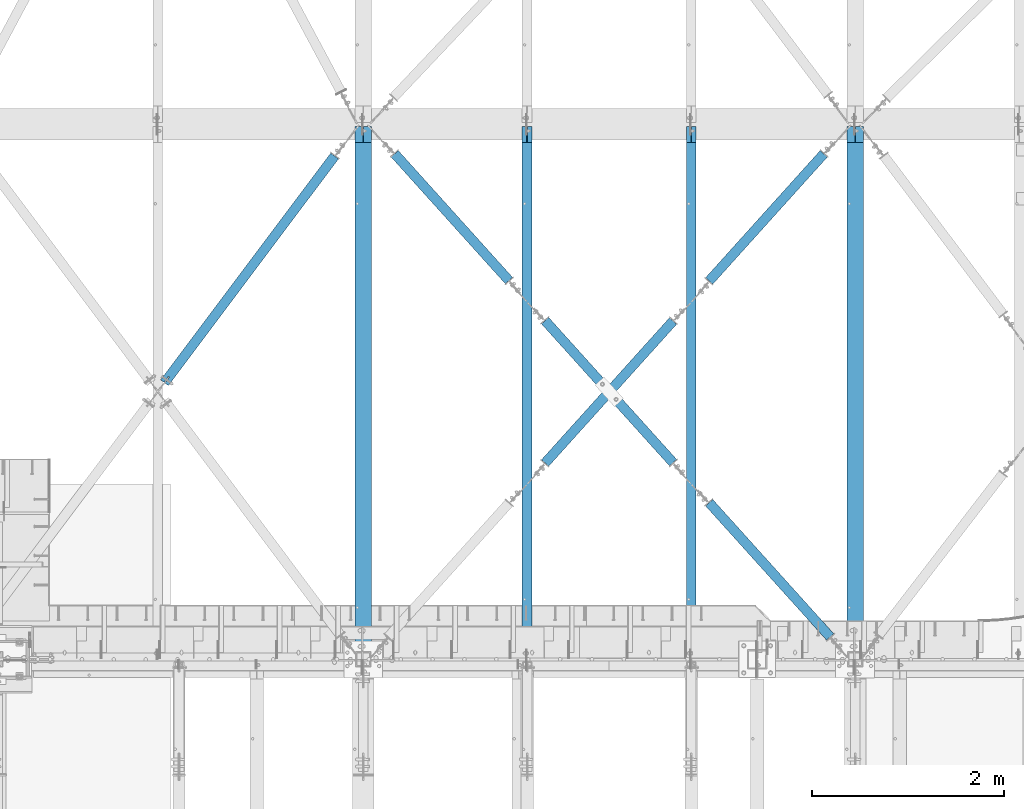
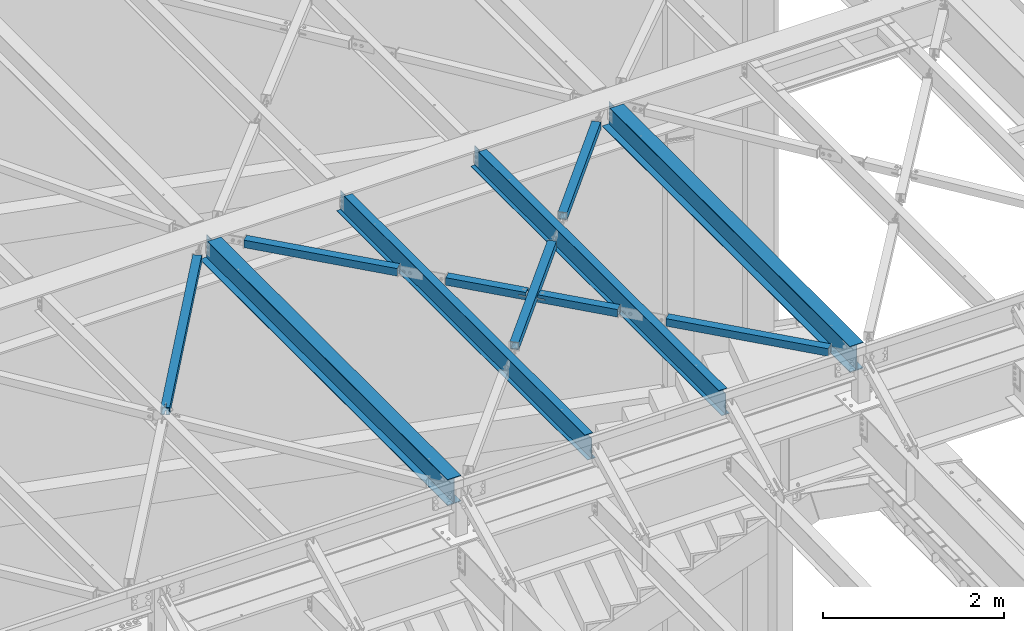
# One storey, part 1166 of 1763: 11 beams, 11 elements without a shape of their own.
"""IFC2X3 building model written with IfcOpenShell, lengths in millimetres."""

from ifc_helpers import new_model, si_unit, frame, origin_with_axes, place, context, subcontext, project, spatial, faceted_brep, material, type_object, element, aggregate, save


model = new_model("IFC2X3")

# Units and contexts
model_context = context("Model", 3, precision=1e-05, world=origin_with_axes())
body_context = subcontext(model_context, "Body", "Model", "MODEL_VIEW")
ifc_project = project(units=[si_unit("LENGTHUNIT", "METRE", prefix="MILLI"), si_unit("AREAUNIT", "SQUARE_METRE"), si_unit("VOLUMEUNIT", "CUBIC_METRE"), si_unit("MASSUNIT", "GRAM", prefix="KILO"), si_unit("TIMEUNIT", "SECOND"), si_unit("PLANEANGLEUNIT", "RADIAN"), si_unit("SOLIDANGLEUNIT", "STERADIAN"), si_unit("THERMODYNAMICTEMPERATUREUNIT", "DEGREE_CELSIUS"), si_unit("LUMINOUSINTENSITYUNIT", "LUMEN")], contexts=[model_context])

# Site, building, storey
site_placement = place(None, origin_with_axes())
site = spatial("IfcSite", under=ifc_project, at=site_placement, CompositionType="ELEMENT")
building_placement = place(site_placement, origin_with_axes())
building = spatial("IfcBuilding", under=site, at=building_placement, Name="Undefined", CompositionType="ELEMENT")
storey_placement = place(building_placement, origin_with_axes())
storey = spatial("IfcBuildingStorey", under=building, at=storey_placement, Name="Undefined", CompositionType="ELEMENT", Elevation=0.0)

# Assembly, beam
assembly_1_placement = place(storey_placement, origin_with_axes())
assembly_1 = element("IfcElementAssembly", 1, at=assembly_1_placement, inside=storey, Name="BEAM", AssemblyPlace="NOTDEFINED", PredefinedType="RIGID_FRAME")
ifc_material_1 = material(Name="STEEL/A992")
beam_type_1 = type_object("IfcBeamType", Name="W14X30", PredefinedType="NOTDEFINED")
beam_1_placement = place(assembly_1_placement, frame((-25976.6096174461, 52044.6000000041, 12269.7875), z_axis=(0.0, 0.0, 1.0), x_axis=(0.0, 1.0, 0.0)))
beam_1 = element("IfcBeam", 2, at=beam_1_placement, type_object=beam_type_1, material=ifc_material_1, Name="BEAM", ObjectType="W14X30", context=body_context, shape_type="Brep", body=[
    faceted_brep([(5465.76249999591, -85.7249999999985, 176.2125), (5465.76249999591, -85.7249999999985, 166.6875), (5465.76249999591, -3.17499999999927, 166.6875), (5465.76249999591, -3.17499999999927, 150.552501487731), (5465.76249999591, 3.17499999999927, 150.552501487731), (5465.76249999591, 3.17499999999927, 166.6875), (5465.76249999591, 85.7249999999985, 166.6875), (5465.76249999591, 85.7249999999985, 176.2125), (5466.7292299185, -3.17499999999927, 145.692421969685), (5466.7292299185, 3.17499999999927, 145.692421969685), (5469.48224381897, -3.17499999999927, 141.572245501531), (5469.48224381897, 3.17499999999927, 141.572245501531), (5473.60242028713, -3.17499999999927, 138.819231601054), (5473.60242028713, 3.17499999999927, 138.819231601054), (5478.46249980517, -3.17499999999927, 137.852501678466), (5478.46249980517, 3.17499999999927, 137.852501678466), (5637.21249999591, -3.17499999999927, 137.852501678466), (5637.21249999591, 3.17499999999927, 137.852501678466), (165.099999996914, -85.7249999999985, -176.2125), (165.099999996914, -85.7249999999985, -166.6875), (165.099999996914, -3.17500000000291, -166.6875), (165.099999996914, -3.17500000000291, 166.6875), (165.099999996914, -85.7249999999985, 166.6875), (165.099999996914, -85.7249999999985, 176.2125), (165.099999996914, 85.7249999999985, 176.2125), (165.099999996914, 85.7249999999985, 166.6875), (165.099999996914, 3.17500000000291, 166.6875), (165.099999996914, 3.17500000000291, -166.6875), (165.099999996914, 85.7249999999985, -166.6875), (165.099999996914, 85.7249999999985, -176.2125), (5637.21249999524, 3.17500000000291, -166.6875), (5637.21249999524, 85.7249999999985, -166.6875), (5637.21249999524, 85.7249999999985, -176.2125), (5637.21249999524, -85.7249999999985, -176.2125), (5637.21249999524, -85.7249999999985, -166.6875), (5637.21249999524, -3.17500000000291, -166.6875)], [[[0, 1, 2, 3, 4, 5, 6, 7]], [[8, 9, 4, 3]], [[10, 11, 9, 8]], [[12, 13, 11, 10]], [[14, 15, 13, 12]], [[16, 17, 15, 14]], [[18, 19, 20, 21, 22, 23, 24, 25, 26, 27, 28, 29]], [[28, 27, 30, 31]], [[29, 28, 31, 32]], [[18, 29, 32, 33]], [[19, 18, 33, 34]], [[20, 19, 34, 35]], [[12, 10, 8, 3, 2, 21, 20, 35, 16, 14]], [[22, 21, 2, 1]], [[23, 22, 1, 0]], [[24, 23, 0, 7]], [[25, 24, 7, 6]], [[26, 25, 6, 5]], [[30, 27, 26, 5, 4, 9, 11, 13, 15, 17]], [[35, 34, 33, 32, 31, 30, 17, 16]]]),
])
aggregate(assembly_1, [beam_1])

assembly_2_placement = place(storey_placement, origin_with_axes())
assembly_2 = element("IfcElementAssembly", 3, at=assembly_2_placement, inside=storey, Name="BEAM", AssemblyPlace="NOTDEFINED", PredefinedType="RIGID_FRAME")
beam_2_placement = place(assembly_2_placement, frame((-31109.3096174444, 52044.6000000041, 12269.7875), z_axis=(0.0, 0.0, 1.0), x_axis=(0.0, 1.0, 0.0)))
beam_2 = element("IfcBeam", 4, at=beam_2_placement, type_object=beam_type_1, material=ifc_material_1, Name="BEAM", ObjectType="W14X30", context=body_context, shape_type="Brep", body=[
    faceted_brep([(5465.76249999591, -85.7249999999985, 176.2125), (5465.76249999591, -85.7249999999985, 166.6875), (5465.76249999591, -3.17499999999927, 166.6875), (5465.76249999591, -3.17499999999927, 150.552501487731), (5465.76249999591, 3.17499999999927, 150.552501487731), (5465.76249999591, 3.17499999999927, 166.6875), (5465.76249999591, 85.7249999999985, 166.6875), (5465.76249999591, 85.7249999999985, 176.2125), (5466.7292299185, -3.17499999999927, 145.692421969685), (5466.7292299185, 3.17499999999927, 145.692421969685), (5469.48224381897, -3.17499999999927, 141.572245501531), (5469.48224381897, 3.17499999999927, 141.572245501531), (5473.60242028713, -3.17499999999927, 138.819231601054), (5473.60242028713, 3.17499999999927, 138.819231601054), (5478.46249980517, -3.17499999999927, 137.852501678466), (5478.46249980517, 3.17499999999927, 137.852501678466), (5637.21249999591, -3.17499999999927, 137.852501678466), (5637.21249999591, 3.17499999999927, 137.852501678466), (165.099999996914, -85.7249999999985, -176.2125), (165.099999996914, -85.7249999999985, -166.6875), (165.099999996914, -3.17500000000291, -166.6875), (165.099999996914, -3.17500000000291, 166.6875), (165.099999996914, -85.7249999999985, 166.6875), (165.099999996914, -85.7249999999985, 176.2125), (165.099999996914, 85.7249999999985, 176.2125), (165.099999996914, 85.7249999999985, 166.6875), (165.099999996914, 3.17500000000291, 166.6875), (165.099999996914, 3.17500000000291, -166.6875), (165.099999996914, 85.7249999999985, -166.6875), (165.099999996914, 85.7249999999985, -176.2125), (5637.21249999524, 3.17500000000291, -166.6875), (5637.21249999524, 85.7249999999985, -166.6875), (5637.21249999524, 85.7249999999985, -176.2125), (5637.21249999524, -85.7249999999985, -176.2125), (5637.21249999524, -85.7249999999985, -166.6875), (5637.21249999524, -3.17500000000291, -166.6875)], [[[0, 1, 2, 3, 4, 5, 6, 7]], [[8, 9, 4, 3]], [[10, 11, 9, 8]], [[12, 13, 11, 10]], [[14, 15, 13, 12]], [[16, 17, 15, 14]], [[18, 19, 20, 21, 22, 23, 24, 25, 26, 27, 28, 29]], [[28, 27, 30, 31]], [[29, 28, 31, 32]], [[18, 29, 32, 33]], [[19, 18, 33, 34]], [[20, 19, 34, 35]], [[12, 10, 8, 3, 2, 21, 20, 35, 16, 14]], [[22, 21, 2, 1]], [[23, 22, 1, 0]], [[24, 23, 0, 7]], [[25, 24, 7, 6]], [[26, 25, 6, 5]], [[30, 27, 26, 5, 4, 9, 11, 13, 15, 17]], [[35, 34, 33, 32, 31, 30, 17, 16]]]),
])
aggregate(assembly_2, [beam_2])

assembly_3_placement = place(storey_placement, origin_with_axes())
assembly_3 = element("IfcElementAssembly", 5, at=assembly_3_placement, inside=storey, Name="H. BRACE", AssemblyPlace="NOTDEFINED", PredefinedType="RIGID_FRAME")
ifc_material_2 = material()
beam_type_2 = type_object("IfcBeamType", Name="HSS4X4X3/8", PredefinedType="NOTDEFINED")
beam_3_placement = place(assembly_3_placement, frame((-28542.959617165, 54911.6250047266, 12371.3875), z_axis=(0.0, 0.0, 1.0), x_axis=(-0.669524421625082, 0.742790043584054, 0.0)))
beam_3 = element("IfcBeam", 6, at=beam_3_placement, type_object=beam_type_2, material=ifc_material_2, Name="H. BRACE", ObjectType="HSS4X4X3/8", context=body_context, shape_type="Brep", body=[
    faceted_brep([(153.987500001618, -50.7999999998865, -6.35000000000036), (153.987500001676, -41.2749999998996, -6.35000000000036), (69.127550659905, -41.2749999998759, -6.35000000000218), (69.1275506598831, -50.7999999998665, -6.35000000000218), (153.987500001618, -50.7999999998865, 6.35000000000036), (153.987500001676, -41.2749999998996, 6.35000000000036), (69.1275506598831, -50.7999999998665, 6.34999999999854), (69.127550659905, -41.2749999998759, 6.34999999999854), (153.9875000022, 41.2749999999687, -6.35000000000036), (153.987500002258, 50.7999999999593, -6.35000000000036), (69.1275506601451, 50.8000000000156, -6.35000000000218), (69.1275506601232, 41.2750000000251, -6.35000000000218), (153.9875000022, 41.2749999999687, 6.35000000000036), (153.987500002258, 50.7999999999593, 6.35000000000036), (69.1275506601232, 41.2750000000251, 6.34999999999854), (69.1275506601451, 50.8000000000156, 6.34999999999854), (69.127550659905, -41.2749999998759, 41.2749999999996), (69.1275506601232, 41.2750000000251, 41.2749999999996), (999.921262668111, 41.2750000010401, 41.2749999999996), (999.921262667893, -41.2749999988719, 41.2749999999996), (69.1275506601451, 50.8000000000156, 50.7999999999993), (999.92126266814, 50.8000000010343, 50.7999999999993), (999.92126266814, 50.8000000010343, -50.7999999999993), (69.1275506601451, 50.8000000000156, -50.7999999999993), (69.1275506598831, -50.7999999998665, -50.7999999999993), (999.921262667871, -50.7999999988624, -50.7999999999993), (69.127550659905, -41.2749999998759, -41.2749999999996), (69.1275506601232, 41.2750000000251, -41.2749999999996), (999.921262667893, -41.2749999988719, -41.2749999999996), (999.921262668111, 41.2750000010401, -41.2749999999996), (999.921262667871, -50.7999999988624, 50.7999999999993), (69.1275506598831, -50.7999999998665, 50.7999999999993)], [[[0, 1, 2, 3]], [[4, 5, 1, 0]], [[6, 7, 5, 4]], [[8, 9, 10, 11]], [[12, 13, 9, 8]], [[14, 15, 13, 12]], [[16, 17, 18, 19]], [[20, 21, 22, 23, 10, 9, 13, 15]], [[24, 23, 22, 25]], [[26, 27, 11, 10, 23, 24, 3, 2]], [[16, 19, 28, 26, 2, 1, 5, 7]], [[27, 26, 28, 29]], [[30, 25, 22, 21], [19, 18, 29, 28]], [[20, 31, 30, 21]], [[3, 24, 25, 30, 31, 6, 4, 0]], [[31, 20, 15, 14, 17, 16, 7, 6]], [[11, 27, 29, 18, 17, 14, 12, 8]]]),
])
aggregate(assembly_3, [beam_3])

assembly_4_placement = place(storey_placement, origin_with_axes())
assembly_4 = element("IfcElementAssembly", 7, at=assembly_4_placement, inside=storey, Name="H. BRACE", AssemblyPlace="NOTDEFINED", PredefinedType="RIGID_FRAME")
beam_4_placement = place(assembly_4_placement, frame((-27688.5696174484, 55859.5103477699, 12371.3875), z_axis=(0.0, 0.0, 1.0), x_axis=(-0.669524421073345, -0.742790044081369, 0.0)))
beam_4 = element("IfcBeam", 8, at=beam_4_placement, type_object=beam_type_2, material=ifc_material_2, Name="H. BRACE", ObjectType="HSS4X4X3/8", context=body_context, shape_type="Brep", body=[
    faceted_brep([(1211.17282522698, 50.799999998635, 6.35000000000036), (1210.18190683964, 41.2749999986409, 6.35000000000036), (1210.18190683964, 41.2749999986409, -6.35000000000036), (1211.17282522698, 50.799999998635, -6.35000000000036), (1350.6356765474, 41.2749999984881, -6.35000000000036), (1351.62658582355, 50.7999999984822, -6.35000000000036), (1350.6356765474, 41.2749999984881, 6.35000000000036), (1351.62658582355, 50.7999999984822, 6.35000000000036), (1201.59394748264, -41.2750000012602, 6.35000000000036), (1200.60302909529, -50.8000000012398, 6.35000000000036), (1200.60302909529, -50.8000000012398, -6.35000000000036), (1201.59394748264, -41.2750000012602, -6.35000000000036), (1341.05688687799, -50.8000000013999, -6.35000000000036), (1342.04779615414, -41.2750000014057, -6.35000000000036), (1341.05688687799, -50.8000000013999, 6.35000000000036), (1342.04779615414, -41.2750000014057, 6.35000000000036), (280.943143919714, -50.8000000002576, -50.7999999999993), (280.943143919434, 50.7999999996318, -50.7999999999993), (2275.93775748132, 50.7999999974709, -50.7999999999993), (2275.9377574816, -50.800000002404, -50.7999999999993), (280.943143919434, 50.7999999996318, 50.7999999999993), (280.943143919714, -50.8000000002576, 50.7999999999993), (2275.9377574816, -50.800000002404, 50.7999999999993), (2275.93775748132, 50.7999999974709, 50.7999999999993), (280.94314391946, 41.2749999996377, 41.2749999999996), (280.943143919689, -41.2750000002634, 41.2749999999996), (280.943143919689, -41.2750000002634, -41.2749999999996), (280.94314391946, 41.2749999996377, -41.2749999999996), (2275.93775748134, 41.2749999974912, -41.2749999999996), (2275.93775748134, 41.2749999974912, 41.2749999999996), (2275.93775748157, -41.2750000024098, 41.2749999999996), (2275.93775748157, -41.2750000024098, -41.2749999999996)], [[[0, 1, 2, 3]], [[3, 2, 4, 5]], [[5, 4, 6, 7]], [[7, 6, 1, 0]], [[8, 9, 10, 11]], [[11, 10, 12, 13]], [[13, 12, 14, 15]], [[15, 14, 9, 8]], [[16, 17, 18, 19]], [[20, 21, 22, 23]], [[17, 20, 23, 18], [3, 5, 7, 0]], [[16, 21, 20, 17], [24, 25, 26, 27]], [[24, 27, 28, 29], [2, 1, 6, 4]], [[25, 24, 29, 30]], [[26, 25, 30, 31], [11, 13, 15, 8]], [[27, 26, 31, 28]], [[22, 19, 18, 23], [30, 29, 28, 31]], [[21, 16, 19, 22], [10, 9, 14, 12]]]),
])
aggregate(assembly_4, [beam_4])

assembly_5_placement = place(storey_placement, origin_with_axes())
assembly_5 = element("IfcElementAssembly", 9, at=assembly_5_placement, inside=storey, Name="H. BRACE", AssemblyPlace="NOTDEFINED", PredefinedType="RIGID_FRAME")
beam_5_placement = place(assembly_5_placement, frame((-27688.5696174484, 53963.7396616777, 12371.3875), z_axis=(0.0, 0.0, 1.0), x_axis=(-0.669524421625082, 0.742790043584054, 0.0)))
beam_5 = element("IfcBeam", 10, at=beam_5_placement, type_object=beam_type_2, material=ifc_material_2, Name="H. BRACE", ObjectType="HSS4X4X3/8", context=body_context, shape_type="Brep", body=[
    faceted_brep([(1206.98721501059, -50.7999999986368, -6.35000000000218), (1206.98721501062, -41.2749999986463, -6.35000000000218), (1122.12711003944, -41.2749999987409, -6.35000000000218), (1122.12706426293, -50.7999999987314, -6.35000000000218), (1122.12711003944, -41.2749999987409, 6.34999999999854), (1122.12706426293, -50.7999999987314, 6.34999999999854), (1206.98721501059, -50.7999999986368, 6.34999999999854), (1206.98721501062, -41.2749999986463, 6.34999999999854), (1206.98721501083, 41.275000001262, -6.35000000000218), (1206.98721501085, 50.8000000012526, -6.35000000000218), (1122.12755254569, 50.8000000011652, -6.35000000000218), (1122.12750676918, 41.2750000011747, -6.35000000000218), (1122.12755254569, 50.8000000011652, 6.34999999999854), (1122.12750676918, 41.2750000011747, 6.34999999999854), (1206.98721501083, 41.275000001262, 6.34999999999854), (1206.98721501085, 50.8000000012526, 6.34999999999854), (281.041414766849, -41.2749999996504, 41.2749999999996), (281.041414767074, 41.2750000002616, 41.2749999999996), (1206.98721501083, 41.275000001262, 41.2749999999996), (1206.98721501062, -41.2749999986463, 41.2749999999996), (1206.98721501062, -41.2749999986463, -41.2749999999996), (281.041414766849, -41.2749999996504, -41.2749999999996), (281.041414767074, 41.2750000002616, -41.2749999999996), (1206.98721501083, 41.275000001262, -41.2749999999996), (281.041414766827, -50.7999999996409, -50.7999999999993), (281.041414766827, -50.7999999996409, 50.7999999999993), (281.041414767104, 50.8000000002448, 50.7999999999993), (281.041414767104, 50.8000000002448, -50.7999999999993), (1206.98721501059, -50.7999999986368, 50.7999999999993), (1206.98721501085, 50.8000000012526, 50.7999999999993), (1206.98721501085, 50.8000000012526, -50.7999999999993), (1206.98721501059, -50.7999999986368, -50.7999999999993)], [[[0, 1, 2, 3]], [[3, 2, 4, 5]], [[6, 5, 4, 7]], [[8, 9, 10, 11]], [[11, 10, 12, 13]], [[14, 13, 12, 15]], [[16, 17, 18, 19]], [[2, 1, 20, 21, 16, 19, 7, 4]], [[22, 21, 20, 23]], [[24, 25, 26, 27], [17, 16, 21, 22]], [[26, 25, 28, 29]], [[19, 18, 14, 15, 29, 28, 6, 7]], [[10, 9, 30, 27, 26, 29, 15, 12]], [[24, 27, 30, 31]], [[28, 25, 24, 31, 0, 3, 5, 6]], [[31, 30, 9, 8, 23, 20, 1, 0]], [[18, 17, 22, 23, 8, 11, 13, 14]]]),
])
aggregate(assembly_5, [beam_5])

assembly_6_placement = place(storey_placement, origin_with_axes())
assembly_6 = element("IfcElementAssembly", 11, at=assembly_6_placement, inside=storey, Name="H. BRACE", AssemblyPlace="NOTDEFINED", PredefinedType="RIGID_FRAME")
beam_6_placement = place(assembly_6_placement, frame((-29400.5296174484, 55863.0383337515, 12371.3875), z_axis=(0.0, 0.0, 1.0), x_axis=(-0.669524421625082, 0.742790043584054, 0.0)))
beam_6 = element("IfcBeam", 12, at=beam_6_placement, type_object=beam_type_2, material=ifc_material_2, Name="H. BRACE", ObjectType="HSS4X4X3/8", context=body_context, shape_type="Brep", body=[
    faceted_brep([(281.041414767074, 41.2750000002616, -41.2749999999996), (281.041414766849, -41.2749999996504, -41.2749999999996), (2062.37065581884, -41.2749999992793, -41.2749999999996), (2062.37065581906, 41.2750000005417, -41.2749999999996), (281.041414766849, -41.2749999996504, 41.2749999999996), (2062.37065581884, -41.2749999992793, 41.2749999999996), (281.041414767074, 41.2750000002616, 41.2749999999996), (2062.37065581906, 41.2750000005417, 41.2749999999996), (281.041414767104, 50.8000000002448, -50.7999999999993), (281.041414767104, 50.8000000002448, 50.7999999999993), (2062.37065581909, 50.8000000005177, 50.7999999999993), (2062.37065581909, 50.8000000005177, -50.7999999999993), (281.041414766827, -50.7999999996409, 50.7999999999993), (2062.37065581881, -50.7999999992589, 50.7999999999993), (281.041414766827, -50.7999999996409, -50.7999999999993), (2062.37065581881, -50.7999999992589, -50.7999999999993)], [[[0, 1, 2, 3]], [[1, 4, 5, 2]], [[4, 6, 7, 5]], [[6, 0, 3, 7]], [[8, 9, 10, 11]], [[9, 12, 13, 10]], [[12, 14, 15, 13]], [[14, 8, 11, 15]], [[13, 15, 11, 10], [5, 7, 3, 2]], [[14, 12, 9, 8], [6, 4, 1, 0]]]),
])
aggregate(assembly_6, [beam_6])

assembly_7_placement = place(storey_placement, origin_with_axes())
assembly_7 = element("IfcElementAssembly", 13, at=assembly_7_placement, inside=storey, Name="H. BRACE", AssemblyPlace="NOTDEFINED", PredefinedType="RIGID_FRAME")
beam_7_placement = place(assembly_7_placement, frame((-31160.1096149185, 57702.4499981051, 12371.3875), z_axis=(0.0, 0.0, 1.0), x_axis=(-0.600137979714526, -0.799896496619511, 0.0)))
beam_7 = element("IfcBeam", 14, at=beam_7_placement, type_object=beam_type_2, material=ifc_material_2, Name="H. BRACE", ObjectType="HSS4X4X3/8", context=body_context, shape_type="Brep", body=[
    faceted_brep([(3371.09186721827, 6.34996521882567, 50.7999999999993), (3293.80214573176, 6.34999989149219, 50.7999999999993), (3293.80214573176, 6.34999989149219, 41.2749999999996), (3371.09186721827, 6.34996521882567, 41.2749999999996), (3293.80214003455, -6.35000010859949, 50.7999999999993), (3293.80214003455, -6.35000010859949, 41.2749999999996), (3371.0918672183, -6.35003478124418, 50.7999999999993), (3371.0918672183, -6.35003478124418, 41.2749999999996), (3371.09186721827, 6.34996521882567, -41.2749999999996), (3293.80214573176, 6.34999989149219, -41.2749999999996), (3293.80214573176, 6.34999989149219, -50.7999999999993), (3371.09186721827, 6.34996521882567, -50.7999999999993), (3293.80214003455, -6.35000010859949, -41.2749999999996), (3293.80214003455, -6.35000010859949, -50.7999999999993), (3371.0918672183, -6.35003478124418, -41.2749999999996), (3371.0918672183, -6.35003478124418, -50.7999999999993), (413.146953942767, 41.2749999992084, 41.2749999999996), (413.146953942767, 41.2749999992084, -41.2749999999996), (3371.09186721819, 41.2749999925363, -41.2749999999996), (3371.09186721819, 41.2749999925363, 41.2749999999996), (3371.09186721838, -41.2750000076339, 41.2749999999996), (413.146953942756, -41.2750000010274, 41.2749999999996), (413.146953942756, -41.2750000010274, -41.2749999999996), (3371.09186721838, -41.2750000076339, -41.2749999999996), (413.146953942764, -50.8000000010579, -50.7999999999993), (413.146953942764, -50.8000000010579, 50.7999999999993), (413.14695394276, 50.7999999992317, 50.7999999999993), (413.14695394276, 50.7999999992317, -50.7999999999993), (3371.09186721817, 50.7999999925596, 50.7999999999993), (3371.09186721817, 50.7999999925596, -50.7999999999993), (3371.09186721839, -50.8000000076499, -50.7999999999993), (3371.09186721839, -50.8000000076499, 50.7999999999993)], [[[0, 1, 2, 3]], [[4, 5, 2, 1]], [[6, 7, 5, 4]], [[8, 9, 10, 11]], [[12, 13, 10, 9]], [[14, 15, 13, 12]], [[16, 17, 18, 19]], [[20, 21, 16, 19, 3, 2, 5, 7]], [[22, 21, 20, 23]], [[9, 8, 18, 17, 22, 23, 14, 12]], [[24, 25, 26, 27], [16, 21, 22, 17]], [[27, 26, 28, 29]], [[19, 18, 8, 11, 29, 28, 0, 3]], [[30, 24, 27, 29, 11, 10, 13, 15]], [[25, 24, 30, 31]], [[1, 0, 28, 26, 25, 31, 6, 4]], [[31, 30, 15, 14, 23, 20, 7, 6]]]),
])
aggregate(assembly_7, [beam_7])

assembly_8_placement = place(storey_placement, origin_with_axes())
assembly_8 = element("IfcElementAssembly", 15, at=assembly_8_placement, inside=storey, Name="H. BRACE", AssemblyPlace="NOTDEFINED", PredefinedType="RIGID_FRAME")
beam_8_placement = place(assembly_8_placement, frame((-26027.4096194441, 57702.4499984928, 12371.3875), z_axis=(0.0, 0.0, 1.0), x_axis=(-0.669524421073345, -0.742790044081369, 0.0)))
beam_8 = element("IfcBeam", 16, at=beam_8_placement, type_object=beam_type_2, material=ifc_material_2, Name="H. BRACE", ObjectType="HSS4X4X3/8", context=body_context, shape_type="Brep", body=[
    faceted_brep([(413.984113952411, 41.2750000001179, -41.2749999999996), (413.984113952432, -41.2749999997031, -41.2749999999996), (2200.06299866677, -41.27499999883, -41.2749999999996), (2200.06299866674, 41.2750000009837, -41.2749999999996), (413.984113952432, -41.2749999997031, 41.2749999999996), (2200.06299866677, -41.27499999883, 41.2749999999996), (413.984113952411, 41.2750000001179, 41.2749999999996), (2200.06299866674, 41.2750000009837, 41.2749999999996), (413.984113952411, 50.8000000000975, -50.7999999999993), (413.984113952411, 50.8000000000975, 50.7999999999993), (2200.06299866674, 50.8000000009633, 50.7999999999993), (2200.06299866674, 50.8000000009633, -50.7999999999993), (413.98411395244, -50.7999999996828, 50.7999999999993), (2200.06299866677, -50.7999999988097, 50.7999999999993), (413.98411395244, -50.7999999996828, -50.7999999999993), (2200.06299866677, -50.7999999988097, -50.7999999999993)], [[[0, 1, 2, 3]], [[1, 4, 5, 2]], [[4, 6, 7, 5]], [[6, 0, 3, 7]], [[8, 9, 10, 11]], [[9, 12, 13, 10]], [[12, 14, 15, 13]], [[14, 8, 11, 15]], [[13, 15, 11, 10], [5, 7, 3, 2]], [[14, 12, 9, 8], [6, 4, 1, 0]]]),
])
aggregate(assembly_8, [beam_8])

assembly_9_placement = place(storey_placement, origin_with_axes())
assembly_9 = element("IfcElementAssembly", 17, at=assembly_9_placement, inside=storey, Name="H. BRACE", AssemblyPlace="NOTDEFINED", PredefinedType="RIGID_FRAME")
beam_9_placement = place(assembly_9_placement, frame((-26027.4096168672, 52120.8, 12371.3875), z_axis=(0.0, 0.0, 1.0), x_axis=(-0.669524421625082, 0.742790043584054, 0.0)))
beam_9 = element("IfcBeam", 18, at=beam_9_placement, type_object=beam_type_2, material=ifc_material_2, Name="H. BRACE", ObjectType="HSS4X4X3/8", context=body_context, shape_type="Brep", body=[
    faceted_brep([(314.162377314518, 41.2750000002943, -41.2749999999996), (314.162377314286, -41.274999999614, -41.2749999999996), (2200.16127633554, -41.2749999975695, -41.2749999999996), (2200.16127633578, 41.2750000023461, -41.2749999999996), (314.162377314286, -41.274999999614, 41.2749999999996), (2200.16127633554, -41.2749999975695, 41.2749999999996), (314.162377314518, 41.2750000002943, 41.2749999999996), (2200.16127633578, 41.2750000023461, 41.2749999999996), (314.162377314533, 50.8000000002849, -50.7999999999993), (314.162377314533, 50.8000000002849, 50.7999999999993), (2200.16127633579, 50.8000000023367, 50.7999999999993), (2200.16127633579, 50.8000000023367, -50.7999999999993), (314.162377314271, -50.7999999996046, 50.7999999999993), (2200.16127633552, -50.79999999756, 50.7999999999993), (314.162377314271, -50.7999999996046, -50.7999999999993), (2200.16127633552, -50.79999999756, -50.7999999999993)], [[[0, 1, 2, 3]], [[1, 4, 5, 2]], [[4, 6, 7, 5]], [[6, 0, 3, 7]], [[8, 9, 10, 11]], [[9, 12, 13, 10]], [[12, 14, 15, 13]], [[14, 8, 11, 15]], [[13, 15, 11, 10], [5, 7, 3, 2]], [[14, 12, 9, 8], [6, 4, 1, 0]]]),
])
aggregate(assembly_9, [beam_9])

assembly_10_placement = place(storey_placement, origin_with_axes())
assembly_10 = element("IfcElementAssembly", 19, at=assembly_10_placement, inside=storey, Name="BEAM", AssemblyPlace="NOTDEFINED", PredefinedType="RIGID_FRAME")
beam_type_3 = type_object("IfcBeamType", Name="W12X16", PredefinedType="NOTDEFINED")
beam_10_placement = place(assembly_10_placement, frame((-27688.5696174484, 52120.8, 12293.6), z_axis=(0.0, 0.0, 1.0), x_axis=(0.0, 1.0, 0.0)))
beam_10 = element("IfcBeam", 20, at=beam_10_placement, type_object=beam_type_3, material=ifc_material_1, Name="BEAM", ObjectType="W12X16", context=body_context, shape_type="Brep", body=[
    faceted_brep([(63.5000001907174, -3.17499999999927, 126.740001678467), (63.5000001907174, 3.17499999999927, 126.740001678467), (15.8749999999854, 3.17499999999927, 126.740001678467), (15.8749999999854, -3.17499999999927, 126.740001678467), (68.3600797087638, -3.17499999999927, 127.706731601054), (68.3600797087638, 3.17499999999927, 127.706731601054), (72.4802561769175, -3.17499999999927, 130.459745501532), (72.4802561769175, 3.17499999999927, 130.459745501532), (75.2332700773914, -3.17499999999927, 134.579921969686), (75.2332700773914, 3.17499999999927, 134.579921969686), (76.1999999999825, -3.17499999999927, 139.440001487732), (76.1999999999825, 3.17499999999927, 139.440001487732), (76.1999999999825, -50.7999999999993, 152.4), (76.1999999999825, 50.7999999999993, 152.4), (76.1999999999825, 50.7999999999993, 146.049999999999), (76.1999999999825, 3.17499999999927, 146.049999999999), (76.1999999999825, -3.17499999999927, 146.049999999999), (76.1999999999825, -50.7999999999993, 146.049999999999), (15.8749999999854, -3.17499999999927, -146.049999999999), (15.8749999999854, -50.7999999999993, -146.049999999999), (5561.01249999999, -50.7999999999993, -146.049999999999), (5561.01249999999, -3.17499999999927, -146.049999999999), (15.8749999999854, -50.7999999999993, -152.4), (5561.01249999999, -50.7999999999993, -152.4), (15.8749999999854, 50.7999999999993, -152.4), (5561.01249999999, 50.7999999999993, -152.4), (15.8749999999854, 50.7999999999993, -146.049999999999), (5561.01249999999, 50.7999999999993, -146.049999999999), (15.8749999999854, 3.17499999999927, -146.049999999999), (5561.01249999999, 3.17499999999927, -146.049999999999), (5561.01249999999, 3.17499999999927, 114.040001678466), (5561.01249999999, -3.17499999999927, 114.040001678466), (5402.26249980926, 3.17499999999927, 114.040001678466), (5402.26249980926, -3.17499999999927, 114.040001678466), (5397.40242029121, 3.17499999999927, 115.006731601054), (5397.40242029121, -3.17499999999927, 115.006731601054), (5393.28224382306, 3.17499999999927, 117.759745501531), (5393.28224382306, -3.17499999999927, 117.759745501531), (5390.52922992258, 3.17499999999927, 121.879921969685), (5390.52922992258, -3.17499999999927, 121.879921969685), (5389.56249999999, 3.17499999999927, 126.740001487731), (5389.56249999999, -3.17499999999927, 126.740001487731), (5389.56249999999, -50.7999999999993, 152.4), (5389.56249999999, -50.7999999999993, 146.049999999999), (5389.56249999999, -3.17499999999927, 146.049999999999), (5389.56249999999, 3.17499999999927, 146.049999999999), (5389.56249999999, 50.7999999999993, 146.049999999999), (5389.56249999999, 50.7999999999993, 152.4)], [[[0, 1, 2, 3]], [[4, 5, 1, 0]], [[6, 7, 5, 4]], [[8, 9, 7, 6]], [[10, 11, 9, 8]], [[12, 13, 14, 15, 11, 10, 16, 17]], [[18, 19, 20, 21]], [[19, 22, 23, 20]], [[22, 24, 25, 23]], [[24, 26, 27, 25]], [[26, 28, 29, 27]], [[21, 20, 23, 25, 27, 29, 30, 31]], [[31, 30, 32, 33]], [[33, 32, 34, 35]], [[35, 34, 36, 37]], [[37, 36, 38, 39]], [[39, 38, 40, 41]], [[42, 43, 44, 41, 40, 45, 46, 47]], [[43, 42, 12, 17]], [[44, 43, 17, 16]], [[8, 6, 4, 0, 3, 18, 21, 31, 33, 35, 37, 39, 41, 44, 16, 10]], [[28, 26, 24, 22, 19, 18, 3, 2]], [[45, 40, 38, 36, 34, 32, 30, 29, 28, 2, 1, 5, 7, 9, 11, 15]], [[46, 45, 15, 14]], [[47, 46, 14, 13]], [[42, 47, 13, 12]]]),
])
aggregate(assembly_10, [beam_10])

assembly_11_placement = place(storey_placement, origin_with_axes())
assembly_11 = element("IfcElementAssembly", 21, at=assembly_11_placement, inside=storey, Name="BEAM", AssemblyPlace="NOTDEFINED", PredefinedType="RIGID_FRAME")
beam_11_placement = place(assembly_11_placement, frame((-29400.5296174484, 52120.8, 12293.6), z_axis=(0.0, 0.0, 1.0), x_axis=(0.0, 1.0, 0.0)))
beam_11 = element("IfcBeam", 22, at=beam_11_placement, type_object=beam_type_3, material=ifc_material_1, Name="BEAM", ObjectType="W12X16", context=body_context, shape_type="Brep", body=[
    faceted_brep([(63.5000001907174, -3.17499999999927, 126.740001678467), (63.5000001907174, 3.17499999999927, 126.740001678467), (15.8749999999854, 3.17499999999927, 126.740001678467), (15.8749999999854, -3.17499999999927, 126.740001678467), (68.3600797087638, -3.17499999999927, 127.706731601054), (68.3600797087638, 3.17499999999927, 127.706731601054), (72.4802561769175, -3.17499999999927, 130.459745501532), (72.4802561769175, 3.17499999999927, 130.459745501532), (75.2332700773914, -3.17499999999927, 134.579921969686), (75.2332700773914, 3.17499999999927, 134.579921969686), (76.1999999999825, -3.17499999999927, 139.440001487732), (76.1999999999825, 3.17499999999927, 139.440001487732), (76.1999999999825, -50.7999999999993, 152.4), (76.1999999999825, 50.7999999999993, 152.4), (76.1999999999825, 50.7999999999993, 146.049999999999), (76.1999999999825, 3.17499999999927, 146.049999999999), (76.1999999999825, -3.17499999999927, 146.049999999999), (76.1999999999825, -50.7999999999993, 146.049999999999), (15.8749999999854, -3.17499999999927, -146.049999999999), (15.8749999999854, -50.7999999999993, -146.049999999999), (5561.01249999999, -50.7999999999993, -146.049999999999), (5561.01249999999, -3.17499999999927, -146.049999999999), (15.8749999999854, -50.7999999999993, -152.4), (5561.01249999999, -50.7999999999993, -152.4), (15.8749999999854, 50.7999999999993, -152.4), (5561.01249999999, 50.7999999999993, -152.4), (15.8749999999854, 50.7999999999993, -146.049999999999), (5561.01249999999, 50.7999999999993, -146.049999999999), (15.8749999999854, 3.17499999999927, -146.049999999999), (5561.01249999999, 3.17499999999927, -146.049999999999), (5561.01249999999, 3.17499999999927, 114.040001678466), (5561.01249999999, -3.17499999999927, 114.040001678466), (5402.26249980926, 3.17499999999927, 114.040001678466), (5402.26249980926, -3.17499999999927, 114.040001678466), (5397.40242029121, 3.17499999999927, 115.006731601054), (5397.40242029121, -3.17499999999927, 115.006731601054), (5393.28224382306, 3.17499999999927, 117.759745501531), (5393.28224382306, -3.17499999999927, 117.759745501531), (5390.52922992258, 3.17499999999927, 121.879921969685), (5390.52922992258, -3.17499999999927, 121.879921969685), (5389.56249999999, 3.17499999999927, 126.740001487731), (5389.56249999999, -3.17499999999927, 126.740001487731), (5389.56249999999, -50.7999999999993, 152.4), (5389.56249999999, -50.7999999999993, 146.049999999999), (5389.56249999999, -3.17499999999927, 146.049999999999), (5389.56249999999, 3.17499999999927, 146.049999999999), (5389.56249999999, 50.7999999999993, 146.049999999999), (5389.56249999999, 50.7999999999993, 152.4)], [[[0, 1, 2, 3]], [[4, 5, 1, 0]], [[6, 7, 5, 4]], [[8, 9, 7, 6]], [[10, 11, 9, 8]], [[12, 13, 14, 15, 11, 10, 16, 17]], [[18, 19, 20, 21]], [[19, 22, 23, 20]], [[22, 24, 25, 23]], [[24, 26, 27, 25]], [[26, 28, 29, 27]], [[21, 20, 23, 25, 27, 29, 30, 31]], [[31, 30, 32, 33]], [[33, 32, 34, 35]], [[35, 34, 36, 37]], [[37, 36, 38, 39]], [[39, 38, 40, 41]], [[42, 43, 44, 41, 40, 45, 46, 47]], [[43, 42, 12, 17]], [[44, 43, 17, 16]], [[8, 6, 4, 0, 3, 18, 21, 31, 33, 35, 37, 39, 41, 44, 16, 10]], [[28, 26, 24, 22, 19, 18, 3, 2]], [[45, 40, 38, 36, 34, 32, 30, 29, 28, 2, 1, 5, 7, 9, 11, 15]], [[46, 45, 15, 14]], [[47, 46, 14, 13]], [[42, 47, 13, 12]]]),
])
aggregate(assembly_11, [beam_11])

save(model, "model.ifc")
